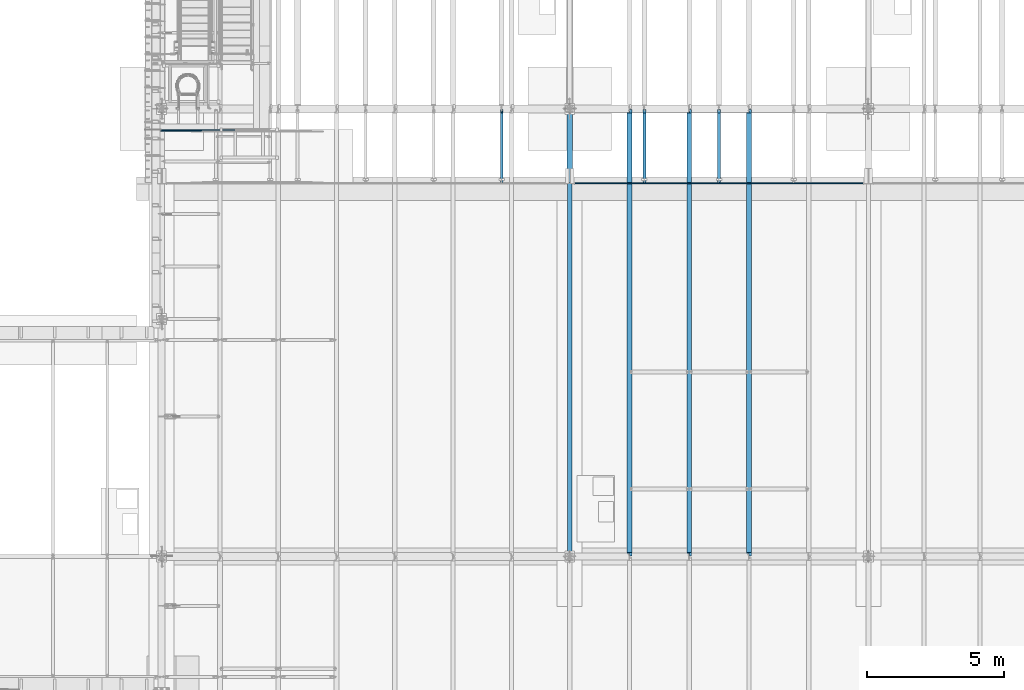
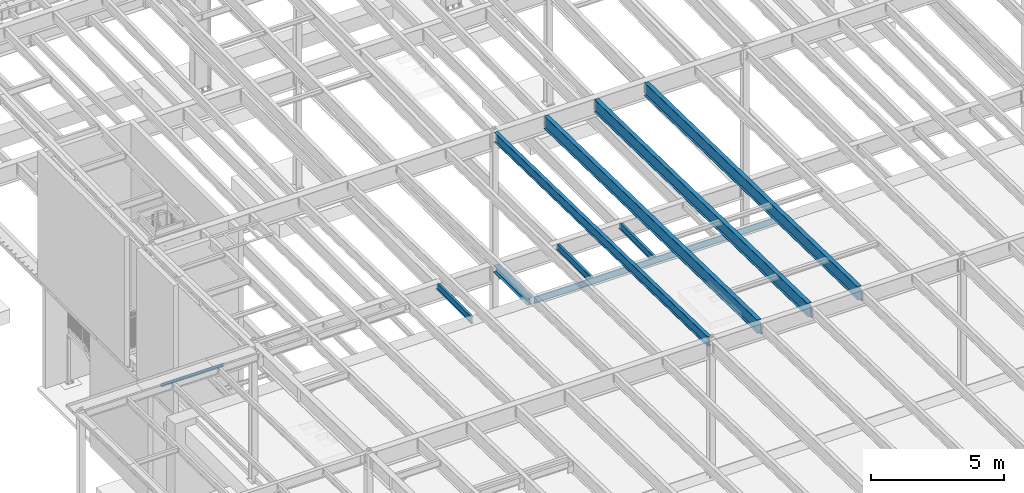
# One storey, part 1076 of 1763: 10 beams, 10 elements without a shape of their own.
"""IFC2X3 building model written with IfcOpenShell, lengths in millimetres."""

import ifcopenshell
import ifcopenshell.guid

model = None  # the IFC model being written
_history = None  # IfcOwnerHistory: only IFC2X3 demands one
_inside = {}  # id of a spatial element -> (the spatial element, [elements in it])
_under = {}  # id of a project, library or spatial element -> (it, [spatial elements below it])
_declared = {}  # id of a project -> (the project, [libraries it declares])
_typed = {}  # id of a type object -> (the type object, [elements of that type])
_made_of = {}  # id of a material, layer set ... -> (it, [elements and type objects made of it])


def new_model(schema):
    """Start an empty IFC model of exactly this schema.

    Asked for "IFC4X3", IfcOpenShell would pick the latest addendum, in which some entities
    have other attributes; the version numbers below select the first issue.
    IFC2X3 requires an IfcOwnerHistory on every rooted entity: one is made here for all.
    """
    global model, _history
    if schema == "IFC4X3":
        model = ifcopenshell.file(schema_version=(4, 3, 0, 0))
    else:
        model = ifcopenshell.file(schema=schema)
    _inside.clear()
    _under.clear()
    _declared.clear()
    _typed.clear()
    _made_of.clear()
    _history = None
    if model.schema == "IFC2X3":
        org = make("IfcOrganization", Name="unknown")
        user = make(
            "IfcPersonAndOrganization",
            ThePerson=make("IfcPerson", FamilyName="unknown"),
            TheOrganization=org,
        )
        app = make(
            "IfcApplication",
            ApplicationDeveloper=org,
            Version="unknown",
            ApplicationFullName="unknown",
            ApplicationIdentifier="unknown",
        )
        _history = make(
            "IfcOwnerHistory",
            OwningUser=user,
            OwningApplication=app,
            ChangeAction="ADDED",
            CreationDate=0,
        )
    return model


def make(cls, **values):
    """One entity of the class cls with the attributes given. An attribute that is None is left unset."""
    return model.create_entity(
        cls, **{name: value for name, value in values.items() if value is not None}
    )


def rooted(cls, **values):
    """An entity with a GlobalId (a new one), such as an element, a storey or a relation."""
    return make(cls, GlobalId=ifcopenshell.guid.new(), OwnerHistory=_history, **values)


def si_unit(unit_type, name, prefix=None):
    """IfcSIUnit, for example si_unit("LENGTHUNIT", "METRE", prefix="MILLI")."""
    return make("IfcSIUnit", UnitType=unit_type, Prefix=prefix, Name=name)


def assignment(units):
    """IfcUnitAssignment: the units of a project."""
    return None if units is None else make("IfcUnitAssignment", Units=units)


def point(xyz):
    """IfcCartesianPoint."""
    return None if xyz is None else make("IfcCartesianPoint", Coordinates=xyz)


def direction(xyz):
    """IfcDirection."""
    return None if xyz is None else make("IfcDirection", DirectionRatios=xyz)


def frame(location, z_axis=None, x_axis=None):
    """IfcAxis2Placement3D, a coordinate frame: its origin and axes. An axis left out is left unset."""
    return make(
        "IfcAxis2Placement3D",
        Location=point(location),
        Axis=direction(z_axis),
        RefDirection=direction(x_axis),
    )


def origin_with_axes():
    """The frame at (0, 0, 0) with the z axis (0, 0, 1) and the x axis (1, 0, 0) written out."""
    return frame((0.0, 0.0, 0.0), z_axis=(0.0, 0.0, 1.0), x_axis=(1.0, 0.0, 0.0))


def place(relative_to, where):
    """IfcLocalPlacement: puts the frame where relative to a parent placement (None: the world)."""
    return make(
        "IfcLocalPlacement", PlacementRelTo=relative_to, RelativePlacement=where
    )


def context(
    kind, dimensions, precision=None, world=None, true_north=None, identifier=None
):
    """IfcGeometricRepresentationContext, for example the 3D "Model" context."""
    return make(
        "IfcGeometricRepresentationContext",
        ContextIdentifier=identifier,
        ContextType=kind,
        CoordinateSpaceDimension=dimensions,
        Precision=precision,
        WorldCoordinateSystem=world,
        TrueNorth=true_north,
    )


def subcontext(parent, identifier, kind, view, scale=None):
    """IfcGeometricRepresentationSubContext, for example "Body" below "Model"."""
    return make(
        "IfcGeometricRepresentationSubContext",
        ContextIdentifier=identifier,
        ContextType=kind,
        ParentContext=parent,
        TargetScale=scale,
        TargetView=view,
    )


def project(units=None, contexts=None):
    """IfcProject with its units and contexts."""
    return rooted(
        "IfcProject",
        Name="project",
        RepresentationContexts=contexts,
        UnitsInContext=assignment(units),
    )


def spatial(cls, under=None, at=None, **own):
    """A site, building, storey or space (cls), placed at a placement, below another one or the project."""
    s = rooted(cls, ObjectPlacement=at, **own)
    if under is not None:
        _under.setdefault(under.id(), (under, []))[1].append(s)
    return s


def faces_of(points, faces, orient=None, outer=None):
    """IfcFace entities. A face is a list of loops; a loop is a list of indices into points, from 0.

    orient and outer hold one flag for each loop. By default every Orientation is true, the
    first loop of a face is its IfcFaceOuterBound and the others are IfcFaceBound.
    """
    made = []
    for i, loops in enumerate(faces):
        bounds = []
        for j, loop in enumerate(loops):
            is_outer = j == 0 if outer is None else outer[i][j]
            bounds.append(
                make(
                    "IfcFaceOuterBound" if is_outer else "IfcFaceBound",
                    Bound=make("IfcPolyLoop", Polygon=[points[k] for k in loop]),
                    Orientation=True if orient is None else orient[i][j],
                )
            )
        made.append(make("IfcFace", Bounds=bounds))
    return made


def faceted_brep(points, faces, orient=None, outer=None, voids=None):
    """IfcFacetedBrep: a solid bounded by flat faces; with voids (closed shells), ...WithVoids."""
    shared = [point(p) for p in points]
    hull = make("IfcClosedShell", CfsFaces=faces_of(shared, faces, orient, outer))
    if voids is None:
        return make("IfcFacetedBrep", Outer=hull)
    return make(
        "IfcFacetedBrepWithVoids",
        Outer=hull,
        Voids=[
            make(cls, CfsFaces=faces_of(shared, fs, o, b)) for cls, fs, o, b in voids
        ],
    )


def shape(context_of_items, identifier, shape_type, items):
    """IfcShapeRepresentation: the items that make up one representation, for example the "Body"."""
    return make(
        "IfcShapeRepresentation",
        ContextOfItems=context_of_items,
        RepresentationIdentifier=identifier,
        RepresentationType=shape_type,
        Items=items,
    )


def material(Name=None, Category=None):
    """IfcMaterial."""
    return make("IfcMaterial", Name=Name, Category=Category)


def made_of(thing, what):
    """Note that an element or type object is made of a material, layer set ...; save() writes the relation."""
    if what is not None:
        _made_of.setdefault(what.id(), (what, []))[1].append(thing)
    return thing


def type_object(cls, material=None, **own):
    """A type object (cls), such as IfcWallType, which elements share."""
    return made_of(rooted(cls, **own), material)


def element(
    cls,
    number,
    at=None,
    inside=None,
    cuts=None,
    type_object=None,
    material=None,
    context=None,
    identifier="Body",
    shape_type=None,
    held_by="IfcProductDefinitionShape",
    body=None,
    shapes=None,
    **own,
):
    """One element of the class cls, such as IfcWall. Its Tag is "e" and its number.

    at: its placement. inside: the storey or other place that contains it. cuts: it is an
    opening in that element (IfcRelVoidsElement). A single representation is given by context,
    identifier, shape_type and body (its items); several are given by shapes. held_by: the class
    of the entity that holds the representations. save() writes the other relations.
    """
    e = rooted(cls, Tag="e%d" % number, ObjectPlacement=at, **own)
    if body is not None:
        shapes = [shape(context, identifier, shape_type, body)]
    if shapes is not None:
        e.Representation = make(held_by, Representations=shapes)
    if inside is not None:
        _inside.setdefault(inside.id(), (inside, []))[1].append(e)
    if cuts is not None:
        rooted(
            "IfcRelVoidsElement", RelatingBuildingElement=cuts, RelatedOpeningElement=e
        )
    if type_object is not None:
        _typed.setdefault(type_object.id(), (type_object, []))[1].append(e)
    return made_of(e, material)


def aggregate(whole, parts):
    """IfcRelAggregates: a whole, such as a stair, and the parts it consists of."""
    return rooted("IfcRelAggregates", RelatingObject=whole, RelatedObjects=parts)


def save(model, path):
    """Write the relations noted so far, then the file.

    IfcRelAggregates (storeys below a building ...), IfcRelContainedInSpatialStructure (elements
    in a storey), IfcRelDefinesByType, IfcRelAssociatesMaterial and IfcRelDeclares: one each for
    every whole, place, type object, material and project.
    """
    for whole, parts in _under.values():
        aggregate(whole, parts)
    for where, things in _inside.values():
        rooted(
            "IfcRelContainedInSpatialStructure",
            RelatedElements=things,
            RelatingStructure=where,
        )
    for kind, things in _typed.values():
        rooted("IfcRelDefinesByType", RelatedObjects=things, RelatingType=kind)
    for what, things in _made_of.values():
        rooted("IfcRelAssociatesMaterial", RelatedObjects=things, RelatingMaterial=what)
    for by, libraries in _declared.values():
        rooted("IfcRelDeclares", RelatingContext=by, RelatedDefinitions=libraries)
    model.write(path)


model = new_model("IFC2X3")

# Units and contexts
model_context = context("Model", 3, precision=1e-05, world=origin_with_axes())
body_context = subcontext(model_context, "Body", "Model", "MODEL_VIEW")
ifc_project = project(units=[si_unit("LENGTHUNIT", "METRE", prefix="MILLI"), si_unit("AREAUNIT", "SQUARE_METRE"), si_unit("VOLUMEUNIT", "CUBIC_METRE"), si_unit("MASSUNIT", "GRAM", prefix="KILO"), si_unit("TIMEUNIT", "SECOND"), si_unit("PLANEANGLEUNIT", "RADIAN"), si_unit("SOLIDANGLEUNIT", "STERADIAN"), si_unit("THERMODYNAMICTEMPERATUREUNIT", "DEGREE_CELSIUS"), si_unit("LUMINOUSINTENSITYUNIT", "LUMEN")], contexts=[model_context])

# Site, building, storey
site_placement = place(None, origin_with_axes())
site = spatial("IfcSite", under=ifc_project, at=site_placement, CompositionType="ELEMENT")
building_placement = place(site_placement, origin_with_axes())
building = spatial("IfcBuilding", under=site, at=building_placement, Name="Undefined", CompositionType="ELEMENT")
storey_placement = place(building_placement, origin_with_axes())
storey = spatial("IfcBuildingStorey", under=building, at=storey_placement, Name="Undefined", CompositionType="ELEMENT", Elevation=0.0)

# Assembly, beam
assembly_1_placement = place(storey_placement, origin_with_axes())
assembly_1 = element("IfcElementAssembly", 1, at=assembly_1_placement, inside=storey, Name="BENT_PLATE", AssemblyPlace="NOTDEFINED", PredefinedType="RIGID_FRAME")
ifc_material_1 = material(Name="STEEL/A36")
beam_type_1 = type_object("IfcBeamType", PredefinedType="NOTDEFINED")
beam_1_placement = place(assembly_1_placement, frame((-86048.2872736984, 29197.2999999971, 5199.0625), z_axis=(-1.0, 0.0, 0.0), x_axis=(0.0, 1.0, 0.0)))
beam_1 = element("IfcBeam", 2, at=beam_1_placement, type_object=beam_type_1, material=ifc_material_1, Name="BENT_PLATE", context=body_context, shape_type="Brep", body=[
    faceted_brep([(0.0, -4.76249999999982, -1365.25), (0.0, -4.76249999999982, 1365.25), (0.0, 4.76249999999982, 1365.25), (0.0, 4.76249999999982, -1365.25), (63.5, 4.76249999999982, 1365.25), (63.5, 4.76249999999982, -1365.25), (53.9749999999985, -4.76249999999982, -1365.25), (53.9749999999985, -4.76249999999982, 1365.25), (63.5, -134.937496948242, 1365.25), (63.5, -134.937496948242, -1365.25), (53.9749999999985, -134.937496948242, 1365.25), (53.9749999999985, -134.937496948242, -1365.25)], [[[0, 1, 2, 3]], [[3, 2, 4, 5]], [[1, 0, 6, 7]], [[5, 4, 8, 9]], [[4, 2, 1, 7, 10, 8]], [[7, 6, 11, 10]], [[6, 0, 3, 5, 9, 11]], [[10, 11, 9, 8]]]),
])
aggregate(assembly_1, [beam_1])

assembly_2_placement = place(storey_placement, origin_with_axes())
assembly_2 = element("IfcElementAssembly", 3, at=assembly_2_placement, inside=storey, Name="BEAM", AssemblyPlace="NOTDEFINED", PredefinedType="RIGID_FRAME")
ifc_material_2 = material(Name="STEEL/A992")
beam_type_2 = type_object("IfcBeamType", Name="W12X16", PredefinedType="NOTDEFINED")
beam_2_placement = place(assembly_2_placement, frame((-67042.7372736984, 27279.6, 5041.9), z_axis=(0.0, 0.0, 1.0), x_axis=(0.0, 1.0, 0.0)))
beam_2 = element("IfcBeam", 4, at=beam_2_placement, type_object=beam_type_2, material=ifc_material_2, Name="BEAM", ObjectType="W12X16", context=body_context, shape_type="Brep", body=[
    faceted_brep([(63.5000000000036, -3.17499999999927, -146.05), (63.5000000000036, -50.7999999999993, -146.05), (2724.15000000001, -50.7999999999993, -146.05), (2724.15000000001, -3.17499999999927, -146.05), (63.5000000000036, -50.7999999999993, -152.4), (2724.15000000001, -50.7999999999993, -152.4), (63.5000000000036, 50.7999999999993, -152.4), (2724.15000000001, 50.7999999999993, -152.4), (63.5000000000036, 50.7999999999993, -146.05), (63.5000000000036, 3.17499999999927, -146.05), (2724.15000000001, 3.17499999999927, -146.05), (2724.15000000001, 50.7999999999993, -146.05), (2724.15000000001, 3.17499999999927, 120.390001678466), (2724.15000000001, -3.17499999999927, 120.390001678466), (63.5000000000036, -3.17499999999927, 146.05), (63.5000000000036, -50.7999999999993, 146.05), (63.5000000000036, -50.7999999999993, 152.4), (63.5000000000036, 50.7999999999993, 152.4), (63.5000000000036, 50.7999999999993, 146.05), (63.5000000000036, 3.17499999999927, 146.05), (2597.15000000001, 50.7999999999993, 146.05), (2597.15000000001, 3.17499999999927, 146.05), (2597.15000000001, 3.17499999999927, 133.090001487731), (2598.11672992259, 3.17499999999927, 128.229921969685), (2600.86974382307, 3.17499999999927, 124.109745501532), (2604.98992029122, 3.17499999999927, 121.356731601053), (2609.84999980927, 3.17499999999927, 120.390001678466), (2598.11672992259, -3.17499999999927, 128.229921969685), (2597.15000000001, -3.17499999999927, 133.090001487731), (2600.86974382307, -3.17499999999927, 124.109745501532), (2604.98992029122, -3.17499999999927, 121.356731601053), (2609.84999980927, -3.17499999999927, 120.390001678466), (2597.15000000001, -3.17499999999927, 146.05), (2597.15000000001, -50.7999999999993, 146.05), (2597.15000000001, -50.7999999999993, 152.4), (2597.15000000001, 50.7999999999993, 152.4)], [[[0, 1, 2, 3]], [[1, 4, 5, 2]], [[4, 6, 7, 5]], [[8, 9, 10, 11]], [[3, 2, 5, 7, 11, 10, 12, 13]], [[6, 8, 11, 7]], [[4, 1, 0, 14, 15, 16, 17, 18, 19, 9, 8, 6]], [[19, 18, 20, 21]], [[10, 9, 19, 21, 22, 23, 24, 25, 26, 12]], [[27, 23, 22, 28]], [[29, 24, 23, 27]], [[30, 25, 24, 29]], [[31, 26, 25, 30]], [[13, 12, 26, 31]], [[30, 29, 27, 28, 32, 14, 0, 3, 13, 31]], [[15, 14, 32, 33]], [[16, 15, 33, 34]], [[17, 16, 34, 35]], [[18, 17, 35, 20]], [[34, 33, 32, 28, 22, 21, 20, 35]]]),
])
aggregate(assembly_2, [beam_2])

assembly_3_placement = place(storey_placement, origin_with_axes())
assembly_3 = element("IfcElementAssembly", 5, at=assembly_3_placement, inside=storey, Name="BEAM", AssemblyPlace="NOTDEFINED", PredefinedType="RIGID_FRAME")
beam_3_placement = place(assembly_3_placement, frame((-69766.8872736983, 27279.6, 5041.9), z_axis=(0.0, 0.0, 1.0), x_axis=(0.0, 1.0, 0.0)))
beam_3 = element("IfcBeam", 6, at=beam_3_placement, type_object=beam_type_2, material=ifc_material_2, Name="BEAM", ObjectType="W12X16", context=body_context, shape_type="Brep", body=[
    faceted_brep([(63.5000000000036, -3.17499999999927, -146.05), (63.5000000000036, -50.7999999999993, -146.05), (2724.15000000001, -50.7999999999993, -146.05), (2724.15000000001, -3.17499999999927, -146.05), (63.5000000000036, -50.7999999999993, -152.4), (2724.15000000001, -50.7999999999993, -152.4), (63.5000000000036, 50.7999999999993, -152.4), (2724.15000000001, 50.7999999999993, -152.4), (63.5000000000036, 50.7999999999993, -146.05), (63.5000000000036, 3.17499999999927, -146.05), (2724.15000000001, 3.17499999999927, -146.05), (2724.15000000001, 50.7999999999993, -146.05), (2724.15000000001, 3.17499999999927, 120.390001678466), (2724.15000000001, -3.17499999999927, 120.390001678466), (63.5000000000036, -3.17499999999927, 146.05), (63.5000000000036, -50.7999999999993, 146.05), (63.5000000000036, -50.7999999999993, 152.4), (63.5000000000036, 50.7999999999993, 152.4), (63.5000000000036, 50.7999999999993, 146.05), (63.5000000000036, 3.17499999999927, 146.05), (2597.15000000001, 50.7999999999993, 146.05), (2597.15000000001, 3.17499999999927, 146.05), (2597.15000000001, 3.17499999999927, 133.090001487731), (2598.11672992259, 3.17499999999927, 128.229921969685), (2600.86974382307, 3.17499999999927, 124.109745501532), (2604.98992029122, 3.17499999999927, 121.356731601053), (2609.84999980927, 3.17499999999927, 120.390001678466), (2598.11672992259, -3.17499999999927, 128.229921969685), (2597.15000000001, -3.17499999999927, 133.090001487731), (2600.86974382307, -3.17499999999927, 124.109745501532), (2604.98992029122, -3.17499999999927, 121.356731601053), (2609.84999980927, -3.17499999999927, 120.390001678466), (2597.15000000001, -3.17499999999927, 146.05), (2597.15000000001, -50.7999999999993, 146.05), (2597.15000000001, -50.7999999999993, 152.4), (2597.15000000001, 50.7999999999993, 152.4)], [[[0, 1, 2, 3]], [[1, 4, 5, 2]], [[4, 6, 7, 5]], [[8, 9, 10, 11]], [[3, 2, 5, 7, 11, 10, 12, 13]], [[6, 8, 11, 7]], [[4, 1, 0, 14, 15, 16, 17, 18, 19, 9, 8, 6]], [[19, 18, 20, 21]], [[10, 9, 19, 21, 22, 23, 24, 25, 26, 12]], [[27, 23, 22, 28]], [[29, 24, 23, 27]], [[30, 25, 24, 29]], [[31, 26, 25, 30]], [[13, 12, 26, 31]], [[30, 29, 27, 28, 32, 14, 0, 3, 13, 31]], [[15, 14, 32, 33]], [[16, 15, 33, 34]], [[17, 16, 34, 35]], [[18, 17, 35, 20]], [[34, 33, 32, 28, 22, 21, 20, 35]]]),
])
aggregate(assembly_3, [beam_3])

assembly_4_placement = place(storey_placement, origin_with_axes())
assembly_4 = element("IfcElementAssembly", 7, at=assembly_4_placement, inside=storey, Name="BEAM", AssemblyPlace="NOTDEFINED", PredefinedType="RIGID_FRAME")
beam_4_placement = place(assembly_4_placement, frame((-74971.7706070317, 27279.6, 5041.9), z_axis=(0.0, 0.0, 1.0), x_axis=(0.0, 1.0, 0.0)))
beam_4 = element("IfcBeam", 8, at=beam_4_placement, type_object=beam_type_2, material=ifc_material_2, Name="BEAM", ObjectType="W12X16", context=body_context, shape_type="Brep", body=[
    faceted_brep([(63.5000000000036, -3.17499999999927, -146.05), (63.5000000000036, -50.7999999999993, -146.05), (2723.35625, -50.8000000000029, -146.05), (2723.35625, -3.17500000000291, -146.05), (63.5000000000036, -50.7999999999993, -152.4), (2723.35625, -50.8000000000029, -152.4), (63.5000000000036, 50.7999999999993, -152.4), (2723.35625, 50.8000000000029, -152.4), (63.5000000000036, 50.7999999999993, -146.05), (63.5000000000036, 3.17499999999927, -146.05), (2723.35625, 3.17500000000291, -146.05), (2723.35625, 50.8000000000029, -146.05), (2723.35625, 3.17500000000291, 120.390001678466), (2723.35625, -3.17500000000291, 120.390001678466), (63.5000000000036, -3.17499999999927, 146.05), (63.5000000000036, -50.7999999999993, 146.05), (63.5000000000036, -50.7999999999993, 152.4), (63.5000000000036, 50.7999999999993, 152.4), (63.5000000000036, 50.7999999999993, 146.05), (63.5000000000036, 3.17499999999927, 146.05), (2583.65625, 50.8000000000029, 146.05), (2583.65625, 3.17500000000291, 146.05), (2583.65625, 3.17500000000291, 133.090001487732), (2584.62297992259, 3.17500000000291, 128.229921969686), (2587.37599382307, 3.17500000000291, 124.109745501532), (2591.49617029122, 3.17500000000291, 121.356731601054), (2596.35624980927, 3.17500000000291, 120.390001678466), (2584.62297992259, -3.17500000000291, 128.229921969686), (2583.65625, -3.17500000000291, 133.090001487732), (2587.37599382307, -3.17500000000291, 124.109745501532), (2591.49617029122, -3.17500000000291, 121.356731601054), (2596.35624980927, -3.17500000000291, 120.390001678466), (2583.65625, -3.17500000000291, 146.05), (2583.65625, -50.8000000000029, 146.05), (2583.65625, -50.8000000000029, 152.4), (2583.65625, 50.8000000000029, 152.4)], [[[0, 1, 2, 3]], [[1, 4, 5, 2]], [[4, 6, 7, 5]], [[8, 9, 10, 11]], [[3, 2, 5, 7, 11, 10, 12, 13]], [[6, 8, 11, 7]], [[4, 1, 0, 14, 15, 16, 17, 18, 19, 9, 8, 6]], [[19, 18, 20, 21]], [[10, 9, 19, 21, 22, 23, 24, 25, 26, 12]], [[27, 23, 22, 28]], [[29, 24, 23, 27]], [[30, 25, 24, 29]], [[31, 26, 25, 30]], [[13, 12, 26, 31]], [[30, 29, 27, 28, 32, 14, 0, 3, 13, 31]], [[15, 14, 32, 33]], [[16, 15, 33, 34]], [[17, 16, 34, 35]], [[18, 17, 35, 20]], [[34, 33, 32, 28, 22, 21, 20, 35]]]),
])
aggregate(assembly_4, [beam_4])

assembly_5_placement = place(storey_placement, origin_with_axes())
assembly_5 = element("IfcElementAssembly", 9, at=assembly_5_placement, inside=storey, Name="BEAM", AssemblyPlace="NOTDEFINED", PredefinedType="RIGID_FRAME")
beam_type_3 = type_object("IfcBeamType", Name="W18X40", PredefinedType="NOTDEFINED")
beam_5_placement = place(assembly_5_placement, frame((-72491.0372736984, 13685.8551306911, 11404.7768219844), z_axis=(0.0, 0.0209013539966291, 0.999781542838788), x_axis=(0.0, 0.999781542776098, -0.0209013569953182)))
beam_5 = element("IfcBeam", 10, at=beam_5_placement, type_object=beam_type_3, material=ifc_material_2, Name="BEAM", ObjectType="W18X40", context=body_context, shape_type="Brep", body=[
    faceted_brep([(149.222337311263, -76.1999999999971, -227.012499999879), (149.222337311263, 76.1999999999971, -227.012499999879), (16200.7664130645, 76.1999999999971, -227.012499990429), (16200.7664130645, -76.1999999999971, -227.012499990429), (148.956832075886, -76.1999999999971, -214.31249999988), (148.956832075886, -3.96875, -214.31249999988), (139.996051629378, -3.96875, 214.31249999976), (139.996051629378, -76.1999999999971, 214.31249999976), (139.730529250521, -76.1999999999971, 227.012499999752), (139.730529250521, 76.1999999999971, 227.012499999752), (139.996051629378, 76.1999999999971, 214.31249999976), (139.996051629378, 3.96875, 214.31249999976), (148.956832075886, 3.96875, -214.31249999988), (148.956832075886, 76.1999999999971, -214.31249999988), (16200.5009078292, -76.1999999999971, -214.31249999043), (16200.5009078292, -3.96875, -214.31249999043), (16191.5401061352, -3.96875, 214.312500009502), (16191.5401061352, -76.1999999999971, 214.312500009502), (16191.2746008998, -76.1999999999971, 227.012500009499), (16191.2746008998, 76.1999999999971, 227.012500009499), (16191.5401061352, 76.1999999999971, 214.312500009502), (16191.5401061352, 3.96875, 214.312500009502), (16200.5009078292, 3.96875, -214.31249999043), (16200.5009078292, 76.1999999999971, -214.31249999043)], [[[0, 1, 2, 3]], [[0, 4, 5, 6, 7, 8, 9, 10, 11, 12, 13, 1]], [[5, 4, 14, 15]], [[6, 5, 15, 16]], [[7, 6, 16, 17]], [[8, 7, 17, 18]], [[9, 8, 18, 19]], [[10, 9, 19, 20]], [[11, 10, 20, 21]], [[12, 11, 21, 22]], [[13, 12, 22, 23]], [[1, 13, 23, 2]], [[22, 21, 20, 19, 18, 17, 16, 15, 14, 3, 2, 23]], [[4, 0, 3, 14]]]),
])
aggregate(assembly_5, [beam_5])

assembly_6_placement = place(storey_placement, origin_with_axes())
assembly_6 = element("IfcElementAssembly", 11, at=assembly_6_placement, inside=storey, Name="BEAM", AssemblyPlace="NOTDEFINED", PredefinedType="RIGID_FRAME")
beam_type_4 = type_object("IfcBeamType", Name="W24X55", PredefinedType="NOTDEFINED")
beam_6_placement = place(assembly_6_placement, frame((-65953.0772736983, 13684.3288091177, 11331.7677748226), z_axis=(0.0, 0.0209013539966291, 0.999781542838788), x_axis=(0.0, 0.999781542776098, -0.0209013569953182)))
beam_6 = element("IfcBeam", 12, at=beam_6_placement, type_object=beam_type_4, material=ifc_material_2, Name="BEAM", ObjectType="W24X55", context=body_context, shape_type="Brep", body=[
    faceted_brep([(133.276735678402, 5.06239015421306, -287.33749999988), (133.27673567837, 5.06260677680257, -300.037499999875), (31.5992848698024, 5.06259305038839, -300.037499999935), (31.333779634424, 5.06237639200117, -287.337499999938), (133.276724360629, 88.8999999999942, -287.337499999878), (133.276724360634, 88.8999999999942, -300.037499999875), (152.326723683869, -4.76249999999709, 268.027501487777), (152.326723683869, 4.76249999999709, 268.027501487777), (151.359993761283, 4.76249999999709, 263.167421969734), (151.359993761283, -4.76249999999709, 263.167421969734), (148.60697986081, 4.76249999999709, 259.047245501581), (148.60697986081, -4.76249999999709, 259.047245501581), (144.486803392658, 4.76249999999709, 256.294231601099), (144.486803392658, -4.76249999999709, 256.294231601099), (139.626723874617, 4.76249999999709, 255.32750167851), (139.626723874617, -4.76249999999709, 255.32750167851), (19.9888663272159, 4.76249999999709, 255.327501678439), (19.9888663272159, -4.76249999999709, 255.327501678439), (31.333779634424, -4.76249999999709, -287.337499999938), (16328.2001979324, -4.76249999999709, -287.337499990341), (16316.8552846223, -4.76249999999709, 255.32750182257), (16188.8431417824, -4.76249999999709, 255.327501822494), (16183.9830622644, -4.76249999999709, 256.29423174508), (16179.8628857962, -4.76249999999709, 259.047245645552), (16177.1098718957, -4.76249999999709, 263.167422113704), (16176.1431419731, -4.76249999999709, 268.027501631745), (16176.1431419731, -4.76249999999709, 287.337500009484), (152.326723683856, -4.76249999999709, 287.337500000051), (31.333779634424, -88.8999999999942, -287.337499999938), (16328.2001979324, -88.9000000000015, -287.337499990341), (31.5992848698024, -88.8999999999942, -300.037499999935), (16328.4657031678, -88.9000000000015, -300.037499990338), (16220.5931397939, 5.06260677258251, -287.337499990406), (16220.5931397939, 5.0623901446379, -300.037499990403), (16220.5931333389, 88.8999999999942, -300.037499990403), (16220.5931333389, 88.8999999999942, -287.337499990404), (16328.4657031678, 5.06239843160438, -300.037499990338), (16328.2001979324, 5.06261502674897, -287.337499990341), (16328.2001979324, 4.76249999999709, -287.337499990341), (16316.8552846223, 4.76249999999709, 255.32750182257), (16188.8431417824, 4.76249999999709, 255.327501822494), (16183.9830622644, 4.76249999999709, 256.29423174508), (16179.8628857962, 4.76249999999709, 259.047245645552), (16177.1098718957, 4.76249999999709, 263.167422113704), (16176.1431419731, 4.76249999999709, 268.027501631745), (16176.1431419731, -88.9000000000015, 300.037500009483), (16176.1431419731, -88.9000000000015, 287.337500009484), (16176.1431419731, 4.76249999999709, 287.337500009484), (16176.1431419731, 88.9000000000015, 287.337500009484), (16176.1431419731, 88.9000000000015, 300.037500009483), (152.326723683856, 4.76249999999709, 287.337500000051), (152.326723683856, 88.8999999999942, 287.337500000051), (152.326723683849, 88.8999999999942, 300.037500000048), (152.326723683849, -88.8999999999942, 300.037500000048), (152.326723683856, -88.8999999999942, 287.337500000051), (31.333779634424, 4.76249999999709, -287.337499999938)], [[[0, 1, 2, 3]], [[4, 5, 1, 0]], [[6, 7, 8, 9]], [[9, 8, 10, 11]], [[11, 10, 12, 13]], [[13, 12, 14, 15]], [[15, 14, 16, 17]], [[9, 11, 13, 15, 17, 18, 19, 20, 21, 22, 23, 24, 25, 26, 27, 6]], [[18, 28, 29, 19]], [[28, 30, 31, 29]], [[32, 33, 34, 35]], [[36, 33, 32, 37]], [[38, 39, 20, 19, 29, 31, 36, 37]], [[20, 39, 40, 21]], [[21, 40, 41, 22]], [[22, 41, 42, 23]], [[23, 42, 43, 24]], [[24, 43, 44, 25]], [[45, 46, 26, 25, 44, 47, 48, 49]], [[48, 47, 50, 51]], [[49, 48, 51, 52]], [[45, 49, 52, 53]], [[46, 45, 53, 54]], [[26, 46, 54, 27]], [[53, 52, 51, 50, 7, 6, 27, 54]], [[47, 44, 43, 42, 41, 40, 39, 38, 55, 16, 14, 12, 10, 8, 7, 50]], [[30, 28, 18, 17, 16, 55, 3, 2]], [[34, 33, 36, 31, 30, 2, 1, 5]], [[35, 34, 5, 4]], [[55, 38, 37, 32, 35, 4, 0, 3]]]),
])
aggregate(assembly_6, [beam_6])

assembly_7_placement = place(storey_placement, origin_with_axes())
assembly_7 = element("IfcElementAssembly", 13, at=assembly_7_placement, inside=storey, Name="BEAM", AssemblyPlace="NOTDEFINED", PredefinedType="RIGID_FRAME")
beam_7_placement = place(assembly_7_placement, frame((-68132.3972736984, 13684.3288091177, 11331.7677748226), z_axis=(0.0, 0.0209013539966291, 0.999781542838788), x_axis=(0.0, 0.999781542776098, -0.0209013569953182)))
beam_7 = element("IfcBeam", 14, at=beam_7_placement, type_object=beam_type_4, material=ifc_material_2, Name="BEAM", ObjectType="W24X55", context=body_context, shape_type="Brep", body=[
    faceted_brep([(133.276735678402, 5.06239015421306, -287.33749999988), (133.27673567837, 5.06260677680257, -300.037499999875), (31.5992848698024, 5.06259305038839, -300.037499999935), (31.333779634424, 5.06237639200117, -287.337499999938), (133.276724360629, 88.8999999999942, -287.337499999878), (133.276724360634, 88.8999999999942, -300.037499999875), (152.326723683869, -4.76249999999709, 268.027501487777), (152.326723683869, 4.76249999999709, 268.027501487777), (151.359993761283, 4.76249999999709, 263.167421969734), (151.359993761283, -4.76249999999709, 263.167421969734), (148.60697986081, 4.76249999999709, 259.047245501581), (148.60697986081, -4.76249999999709, 259.047245501581), (144.486803392658, 4.76249999999709, 256.294231601099), (144.486803392658, -4.76249999999709, 256.294231601099), (139.626723874617, 4.76249999999709, 255.32750167851), (139.626723874617, -4.76249999999709, 255.32750167851), (19.9888663272159, 4.76249999999709, 255.327501678439), (19.9888663272159, -4.76249999999709, 255.327501678439), (31.333779634424, -4.76249999999709, -287.337499999938), (16328.2001979324, -4.76249999999709, -287.337499990341), (16316.8552846223, -4.76249999999709, 255.32750182257), (16188.8431417824, -4.76249999999709, 255.327501822494), (16183.9830622644, -4.76249999999709, 256.29423174508), (16179.8628857962, -4.76249999999709, 259.047245645552), (16177.1098718957, -4.76249999999709, 263.167422113704), (16176.1431419731, -4.76249999999709, 268.027501631745), (16176.1431419731, -4.76249999999709, 287.337500009484), (152.326723683856, -4.76249999999709, 287.337500000051), (31.333779634424, -88.8999999999942, -287.337499999938), (16328.2001979324, -88.9000000000015, -287.337499990341), (31.5992848698024, -88.8999999999942, -300.037499999935), (16328.4657031678, -88.9000000000015, -300.037499990338), (16220.5931397939, 5.06260677258251, -287.337499990406), (16220.5931397939, 5.0623901446379, -300.037499990403), (16220.5931333389, 88.8999999999942, -300.037499990403), (16220.5931333389, 88.8999999999942, -287.337499990404), (16328.4657031678, 5.06239843160438, -300.037499990338), (16328.2001979324, 5.06261502674897, -287.337499990341), (16328.2001979324, 4.76249999999709, -287.337499990341), (16316.8552846223, 4.76249999999709, 255.32750182257), (16188.8431417824, 4.76249999999709, 255.327501822494), (16183.9830622644, 4.76249999999709, 256.29423174508), (16179.8628857962, 4.76249999999709, 259.047245645552), (16177.1098718957, 4.76249999999709, 263.167422113704), (16176.1431419731, 4.76249999999709, 268.027501631745), (16176.1431419731, -88.9000000000015, 300.037500009483), (16176.1431419731, -88.9000000000015, 287.337500009484), (16176.1431419731, 4.76249999999709, 287.337500009484), (16176.1431419731, 88.9000000000015, 287.337500009484), (16176.1431419731, 88.9000000000015, 300.037500009483), (152.326723683856, 4.76249999999709, 287.337500000051), (152.326723683856, 88.8999999999942, 287.337500000051), (152.326723683849, 88.8999999999942, 300.037500000048), (152.326723683849, -88.8999999999942, 300.037500000048), (152.326723683856, -88.8999999999942, 287.337500000051), (31.333779634424, 4.76249999999709, -287.337499999938)], [[[0, 1, 2, 3]], [[4, 5, 1, 0]], [[6, 7, 8, 9]], [[9, 8, 10, 11]], [[11, 10, 12, 13]], [[13, 12, 14, 15]], [[15, 14, 16, 17]], [[9, 11, 13, 15, 17, 18, 19, 20, 21, 22, 23, 24, 25, 26, 27, 6]], [[18, 28, 29, 19]], [[28, 30, 31, 29]], [[32, 33, 34, 35]], [[36, 33, 32, 37]], [[38, 39, 20, 19, 29, 31, 36, 37]], [[20, 39, 40, 21]], [[21, 40, 41, 22]], [[22, 41, 42, 23]], [[23, 42, 43, 24]], [[24, 43, 44, 25]], [[45, 46, 26, 25, 44, 47, 48, 49]], [[48, 47, 50, 51]], [[49, 48, 51, 52]], [[45, 49, 52, 53]], [[46, 45, 53, 54]], [[26, 46, 54, 27]], [[53, 52, 51, 50, 7, 6, 27, 54]], [[47, 44, 43, 42, 41, 40, 39, 38, 55, 16, 14, 12, 10, 8, 7, 50]], [[30, 28, 18, 17, 16, 55, 3, 2]], [[34, 33, 36, 31, 30, 2, 1, 5]], [[35, 34, 5, 4]], [[55, 38, 37, 32, 35, 4, 0, 3]]]),
])
aggregate(assembly_7, [beam_7])

assembly_8_placement = place(storey_placement, origin_with_axes())
assembly_8 = element("IfcElementAssembly", 15, at=assembly_8_placement, inside=storey, Name="BEAM", AssemblyPlace="NOTDEFINED", PredefinedType="RIGID_FRAME")
beam_8_placement = place(assembly_8_placement, frame((-70311.7172736983, 13684.3288091177, 11331.7677748226), z_axis=(0.0, 0.0209013539966291, 0.999781542838788), x_axis=(0.0, 0.999781542776098, -0.0209013569953182)))
beam_8 = element("IfcBeam", 16, at=beam_8_placement, type_object=beam_type_4, material=ifc_material_2, Name="BEAM", ObjectType="W24X55", context=body_context, shape_type="Brep", body=[
    faceted_brep([(133.276735678402, 5.06239015421306, -287.33749999988), (133.27673567837, 5.06260677680257, -300.037499999875), (31.5992848698024, 5.06259305038839, -300.037499999935), (31.333779634424, 5.06237639200117, -287.337499999938), (133.276724360629, 88.8999999999942, -287.337499999878), (133.276724360634, 88.8999999999942, -300.037499999875), (152.326723683869, -4.76249999999709, 268.027501487777), (152.326723683869, 4.76249999999709, 268.027501487777), (151.359993761283, 4.76249999999709, 263.167421969734), (151.359993761283, -4.76249999999709, 263.167421969734), (148.60697986081, 4.76249999999709, 259.047245501581), (148.60697986081, -4.76249999999709, 259.047245501581), (144.486803392658, 4.76249999999709, 256.294231601099), (144.486803392658, -4.76249999999709, 256.294231601099), (139.626723874617, 4.76249999999709, 255.32750167851), (139.626723874617, -4.76249999999709, 255.32750167851), (19.9888663272159, 4.76249999999709, 255.327501678439), (19.9888663272159, -4.76249999999709, 255.327501678439), (31.333779634424, -4.76249999999709, -287.337499999938), (16328.2001979324, -4.76249999999709, -287.337499990341), (16316.8552846223, -4.76249999999709, 255.32750182257), (16188.8431417824, -4.76249999999709, 255.327501822494), (16183.9830622644, -4.76249999999709, 256.29423174508), (16179.8628857962, -4.76249999999709, 259.047245645552), (16177.1098718957, -4.76249999999709, 263.167422113704), (16176.1431419731, -4.76249999999709, 268.027501631745), (16176.1431419731, -4.76249999999709, 287.337500009484), (152.326723683856, -4.76249999999709, 287.337500000051), (31.333779634424, -88.8999999999942, -287.337499999938), (16328.2001979324, -88.9000000000015, -287.337499990341), (31.5992848698024, -88.8999999999942, -300.037499999935), (16328.4657031678, -88.9000000000015, -300.037499990338), (16220.5931397939, 5.06260677258251, -287.337499990406), (16220.5931397939, 5.0623901446379, -300.037499990403), (16220.5931333389, 88.8999999999942, -300.037499990403), (16220.5931333389, 88.8999999999942, -287.337499990404), (16328.4657031678, 5.06239843160438, -300.037499990338), (16328.2001979324, 5.06261502674897, -287.337499990341), (16328.2001979324, 4.76249999999709, -287.337499990341), (16316.8552846223, 4.76249999999709, 255.32750182257), (16188.8431417824, 4.76249999999709, 255.327501822494), (16183.9830622644, 4.76249999999709, 256.29423174508), (16179.8628857962, 4.76249999999709, 259.047245645552), (16177.1098718957, 4.76249999999709, 263.167422113704), (16176.1431419731, 4.76249999999709, 268.027501631745), (16176.1431419731, -88.9000000000015, 300.037500009483), (16176.1431419731, -88.9000000000015, 287.337500009484), (16176.1431419731, 4.76249999999709, 287.337500009484), (16176.1431419731, 88.9000000000015, 287.337500009484), (16176.1431419731, 88.9000000000015, 300.037500009483), (152.326723683856, 4.76249999999709, 287.337500000051), (152.326723683856, 88.8999999999942, 287.337500000051), (152.326723683849, 88.8999999999942, 300.037500000048), (152.326723683849, -88.8999999999942, 300.037500000048), (152.326723683856, -88.8999999999942, 287.337500000051), (31.333779634424, 4.76249999999709, -287.337499999938)], [[[0, 1, 2, 3]], [[4, 5, 1, 0]], [[6, 7, 8, 9]], [[9, 8, 10, 11]], [[11, 10, 12, 13]], [[13, 12, 14, 15]], [[15, 14, 16, 17]], [[9, 11, 13, 15, 17, 18, 19, 20, 21, 22, 23, 24, 25, 26, 27, 6]], [[18, 28, 29, 19]], [[28, 30, 31, 29]], [[32, 33, 34, 35]], [[36, 33, 32, 37]], [[38, 39, 20, 19, 29, 31, 36, 37]], [[20, 39, 40, 21]], [[21, 40, 41, 22]], [[22, 41, 42, 23]], [[23, 42, 43, 24]], [[24, 43, 44, 25]], [[45, 46, 26, 25, 44, 47, 48, 49]], [[48, 47, 50, 51]], [[49, 48, 51, 52]], [[45, 49, 52, 53]], [[46, 45, 53, 54]], [[26, 46, 54, 27]], [[53, 52, 51, 50, 7, 6, 27, 54]], [[47, 44, 43, 42, 41, 40, 39, 38, 55, 16, 14, 12, 10, 8, 7, 50]], [[30, 28, 18, 17, 16, 55, 3, 2]], [[34, 33, 36, 31, 30, 2, 1, 5]], [[35, 34, 5, 4]], [[55, 38, 37, 32, 35, 4, 0, 3]]]),
])
aggregate(assembly_8, [beam_8])

assembly_9_placement = place(storey_placement, origin_with_axes())
assembly_9 = element("IfcElementAssembly", 17, at=assembly_9_placement, inside=storey, Name="BEAM", AssemblyPlace="NOTDEFINED", PredefinedType="RIGID_FRAME")
beam_type_5 = type_object("IfcBeamType", Name="MC12X10.6", PredefinedType="NOTDEFINED")
beam_9_placement = place(assembly_9_placement, frame((-72308.4747736984, 27311.35, 5041.9), z_axis=(0.0, 0.0, 1.0), x_axis=(1.0, 0.0, 0.0)))
beam_9 = element("IfcBeam", 18, at=beam_9_placement, type_object=beam_type_5, material=ifc_material_2, Name="BEAM", ObjectType="MC12X10.6", context=body_context, shape_type="Brep", body=[
    faceted_brep([(0.0, 19.0499999999993, -152.4), (0.0, 19.0499999999993, 152.4), (10531.475, 19.0499999999993, 152.4), (10531.475, 19.0499999999993, -152.4), (0.0, -19.0499999999993, 152.4), (10531.475, -19.0499999999993, 152.4), (0.0, -19.0499999999993, 144.841595), (10531.475, -19.0499999999993, 144.841595), (0.0, 14.2874999999985, 144.17817875), (10531.475, 14.2874999999985, 144.17817875), (0.0, 14.2874999999985, -144.17817875), (10531.475, 14.2874999999985, -144.17817875), (0.0, -19.0499999999993, -144.841595), (10531.475, -19.0499999999993, -144.841595), (0.0, -19.0499999999993, -152.4), (10531.475, -19.0499999999993, -152.4)], [[[0, 1, 2, 3]], [[1, 4, 5, 2]], [[4, 6, 7, 5]], [[6, 8, 9, 7]], [[8, 10, 11, 9]], [[10, 12, 13, 11]], [[12, 14, 15, 13]], [[14, 0, 3, 15]], [[5, 7, 9, 11, 13, 15, 3, 2]], [[14, 12, 10, 8, 6, 4, 1, 0]]]),
])
aggregate(assembly_9, [beam_9])

assembly_10_placement = place(storey_placement, origin_with_axes())
assembly_10 = element("IfcElementAssembly", 19, at=assembly_10_placement, inside=storey, Name="BEAM", AssemblyPlace="NOTDEFINED", PredefinedType="RIGID_FRAME")
beam_type_6 = type_object("IfcBeamType", Name="W12X50", PredefinedType="NOTDEFINED")
beam_10_placement = place(assembly_10_placement, frame((-72491.0372736984, 27279.6, 5038.725), z_axis=(0.0, 0.0, 1.0), x_axis=(0.0, 1.0, 0.0)))
beam_10 = element("IfcBeam", 20, at=beam_10_placement, type_object=beam_type_6, material=ifc_material_2, Name="BEAM", ObjectType="W12X50", context=body_context, shape_type="Brep", body=[
    faceted_brep([(50.7999999999993, -103.1875, -139.7), (50.7999999999993, -103.1875, -155.575), (2598.7375, -103.1875, -155.575), (2598.7375, -103.1875, -139.7), (50.7999999999993, -4.76250000000073, -139.7), (2598.7375, -4.76249999999709, -139.7), (50.7999999999993, -4.76250000000073, 139.7), (2598.7375, -4.76249999999709, 139.7), (50.7999999999993, -103.1875, 139.7), (2598.7375, -103.1875, 139.7), (50.7999999999993, -103.1875, 155.575), (2598.7375, -103.1875, 155.575), (50.7999999999993, 103.1875, 155.575), (2598.7375, 103.1875, 155.575), (50.7999999999993, 103.1875, 139.7), (2598.7375, 103.1875, 139.7), (50.7999999999993, 4.76250000000073, 139.7), (2598.7375, 4.76249999999709, 139.7), (50.7999999999993, 4.76250000000073, -139.7), (2598.7375, 4.76249999999709, -139.7), (50.7999999999993, 103.1875, -139.7), (2598.7375, 103.1875, -139.7), (50.7999999999993, 103.1875, -155.575), (2598.7375, 103.1875, -155.575)], [[[0, 1, 2, 3]], [[4, 0, 3, 5]], [[6, 4, 5, 7]], [[8, 6, 7, 9]], [[10, 8, 9, 11]], [[12, 10, 11, 13]], [[14, 12, 13, 15]], [[16, 14, 15, 17]], [[18, 16, 17, 19]], [[20, 18, 19, 21]], [[1, 0, 4, 6, 8, 10, 12, 14, 16, 18, 20, 22]], [[1, 22, 23, 2]], [[19, 17, 15, 13, 11, 9, 7, 5, 3, 2, 23, 21]], [[22, 20, 21, 23]]]),
])
aggregate(assembly_10, [beam_10])

save(model, "model.ifc")
